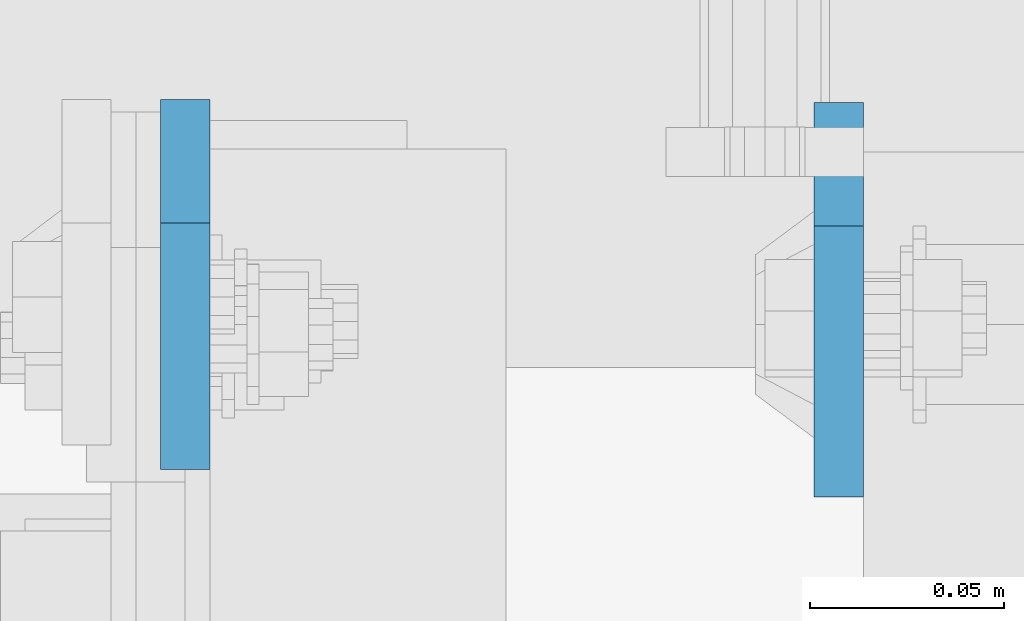
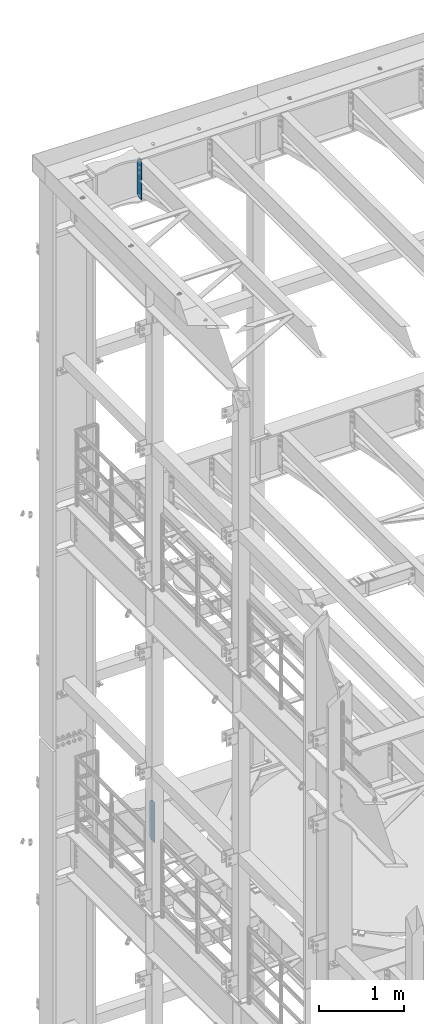
# One storey, part 1774 of 1876: 2 plates, 2 elements without a shape of their own.
"""IFC2X3 building model written with IfcOpenShell, lengths in millimetres."""

from ifc_helpers import new_model, si_unit, frame, origin_with_axes, place, context, subcontext, project, spatial, faceted_brep, material, type_object, element, aggregate, save


model = new_model("IFC2X3")

# Units and contexts
model_context = context("Model", 3, precision=1e-05, world=origin_with_axes())
body_context = subcontext(model_context, "Body", "Model", "MODEL_VIEW")
ifc_project = project(units=[si_unit("LENGTHUNIT", "METRE", prefix="MILLI"), si_unit("AREAUNIT", "SQUARE_METRE"), si_unit("VOLUMEUNIT", "CUBIC_METRE"), si_unit("MASSUNIT", "GRAM", prefix="KILO"), si_unit("TIMEUNIT", "SECOND"), si_unit("PLANEANGLEUNIT", "RADIAN"), si_unit("SOLIDANGLEUNIT", "STERADIAN"), si_unit("THERMODYNAMICTEMPERATUREUNIT", "DEGREE_CELSIUS"), si_unit("LUMINOUSINTENSITYUNIT", "LUMEN")], contexts=[model_context])

# Site, building, storey
site_placement = place(None, origin_with_axes())
site = spatial("IfcSite", under=ifc_project, at=site_placement, CompositionType="ELEMENT")
building_placement = place(site_placement, origin_with_axes())
building = spatial("IfcBuilding", under=site, at=building_placement, Name="Undefined", CompositionType="ELEMENT")
storey_placement = place(building_placement, origin_with_axes())
storey = spatial("IfcBuildingStorey", under=building, at=storey_placement, Name="Undefined", CompositionType="ELEMENT", Elevation=0.0)

# Assembly, plate
assembly_1_placement = place(storey_placement, origin_with_axes())
assembly_1 = element("IfcElementAssembly", 1, at=assembly_1_placement, inside=storey, Name="BEAM", AssemblyPlace="NOTDEFINED", PredefinedType="RIGID_FRAME")
ifc_material = material(Name="STEEL/A36")
plate_type_1 = type_object("IfcPlateType", PredefinedType="NOTDEFINED")
plate_1_placement = place(assembly_1_placement, frame((942.974999904633, 13708.85625, 21959.8875), z_axis=(0.0, 0.0, 1.0), x_axis=(0.0, -1.0, 0.0)))
plate_1 = element("IfcPlate", 2, at=plate_1_placement, type_object=plate_type_1, material=ifc_material, Name="PLATE", context=body_context, shape_type="Brep", body=[
    faceted_brep([(0.0, -6.34999999999991, 31.75), (0.0, -6.35000000000036, 538.162475585938), (0.0, 6.35000000000036, 538.162475585938), (0.0, 6.34999999999991, 31.75), (31.75, -6.35000000000036, 569.912475585938), (31.75, 6.35000000000036, 569.912475585938), (95.25, -6.35000000000036, 569.912475585938), (95.25, 6.35000000000036, 569.912475585938), (95.25, -6.35000000000036, 0.0), (95.25, 6.35000000000036, 0.0), (31.75, -6.34999999999991, 0.0), (31.75, 6.34999999999991, 0.0)], [[[0, 1, 2, 3]], [[1, 4, 5, 2]], [[4, 6, 7, 5]], [[6, 8, 9, 7]], [[8, 10, 11, 9]], [[10, 0, 3, 11]], [[5, 7, 9, 11, 3, 2]], [[10, 8, 6, 4, 1, 0]]]),
])
aggregate(assembly_1, [plate_1])

assembly_2_placement = place(storey_placement, origin_with_axes())
assembly_2 = element("IfcElementAssembly", 3, at=assembly_2_placement, inside=storey, Name="BEAM", AssemblyPlace="NOTDEFINED", PredefinedType="RIGID_FRAME")
plate_type_2 = type_object("IfcPlateType", PredefinedType="NOTDEFINED")
plate_2_placement = place(assembly_2_placement, frame((1111.25000470527, 13708.0625, 12709.525), z_axis=(0.0, 0.0, 1.0), x_axis=(0.0, -1.0, 0.0)))
plate_2 = element("IfcPlate", 4, at=plate_2_placement, type_object=plate_type_2, material=ifc_material, Name="PLATE", context=body_context, shape_type="Brep", body=[
    faceted_brep([(0.0, -6.34999999999991, 31.75), (0.0, -6.35000000000036, 541.337524414062), (0.0, 6.35000000000036, 541.337524414062), (0.0, 6.34999999999991, 31.75), (31.75, -6.35000000000036, 573.087524414062), (31.75, 6.35000000000036, 573.087524414062), (101.599998474121, -6.35000000000036, 573.087524414062), (101.599998474121, 6.35000000000036, 573.087524414062), (101.599998474121, -6.35000000000036, 0.0), (101.599998474121, 6.35000000000036, 0.0), (31.75, -6.34999999999991, 0.0), (31.75, 6.34999999999991, 0.0)], [[[0, 1, 2, 3]], [[1, 4, 5, 2]], [[4, 6, 7, 5]], [[6, 8, 9, 7]], [[8, 10, 11, 9]], [[10, 0, 3, 11]], [[5, 7, 9, 11, 3, 2]], [[10, 8, 6, 4, 1, 0]]]),
])
aggregate(assembly_2, [plate_2])

save(model, "model.ifc")
